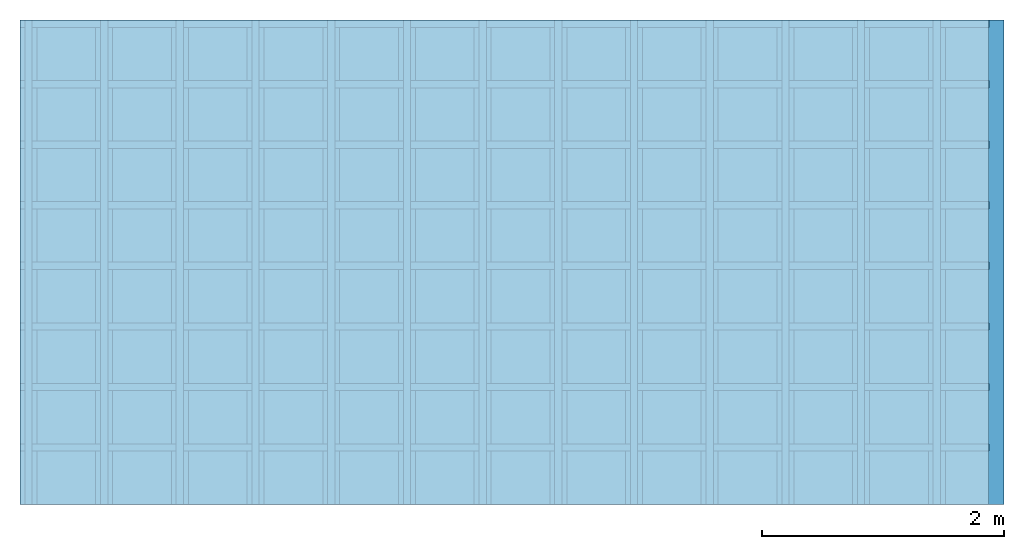
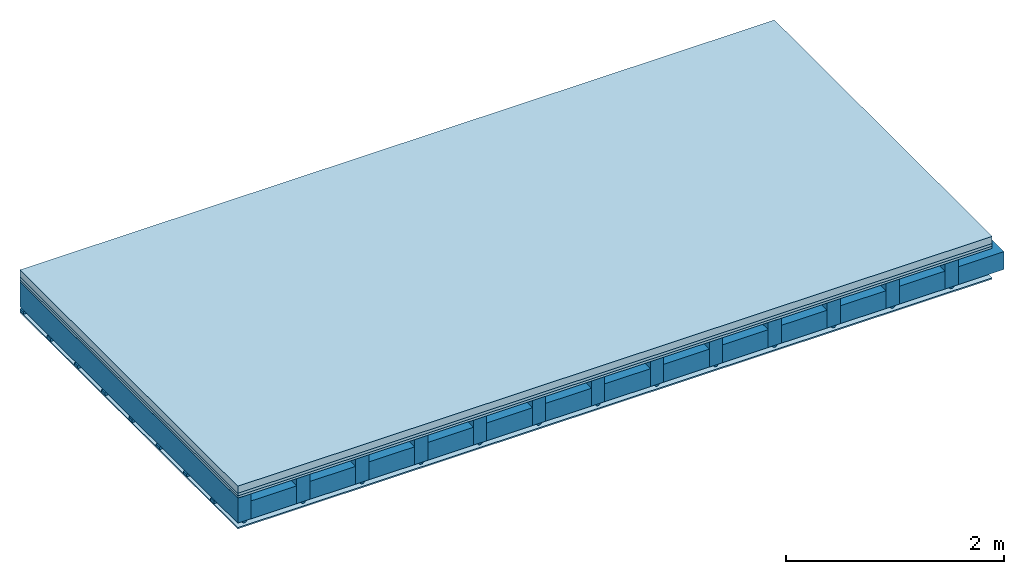
# One storey: 4 members, 4 plates, 1 element without a shape of its own.
"""IFC4 building model written with IfcOpenShell, lengths in metres."""

import ifcopenshell
import ifcopenshell.guid

model = None  # the IFC model being written
_history = None  # IfcOwnerHistory: only IFC2X3 demands one
_inside = {}  # id of a spatial element -> (the spatial element, [elements in it])
_under = {}  # id of a project, library or spatial element -> (it, [spatial elements below it])
_declared = {}  # id of a project -> (the project, [libraries it declares])
_typed = {}  # id of a type object -> (the type object, [elements of that type])
_made_of = {}  # id of a material, layer set ... -> (it, [elements and type objects made of it])


def new_model(schema):
    """Start an empty IFC model of exactly this schema.

    Asked for "IFC4X3", IfcOpenShell would pick the latest addendum, in which some entities
    have other attributes; the version numbers below select the first issue.
    IFC2X3 requires an IfcOwnerHistory on every rooted entity: one is made here for all.
    """
    global model, _history
    if schema == "IFC4X3":
        model = ifcopenshell.file(schema_version=(4, 3, 0, 0))
    else:
        model = ifcopenshell.file(schema=schema)
    _inside.clear()
    _under.clear()
    _declared.clear()
    _typed.clear()
    _made_of.clear()
    _history = None
    if model.schema == "IFC2X3":
        org = make("IfcOrganization", Name="unknown")
        user = make(
            "IfcPersonAndOrganization",
            ThePerson=make("IfcPerson", FamilyName="unknown"),
            TheOrganization=org,
        )
        app = make(
            "IfcApplication",
            ApplicationDeveloper=org,
            Version="unknown",
            ApplicationFullName="unknown",
            ApplicationIdentifier="unknown",
        )
        _history = make(
            "IfcOwnerHistory",
            OwningUser=user,
            OwningApplication=app,
            ChangeAction="ADDED",
            CreationDate=0,
        )
    return model


def make(cls, **values):
    """One entity of the class cls with the attributes given. An attribute that is None is left unset."""
    return model.create_entity(
        cls, **{name: value for name, value in values.items() if value is not None}
    )


def rooted(cls, **values):
    """An entity with a GlobalId (a new one), such as an element, a storey or a relation."""
    return make(cls, GlobalId=ifcopenshell.guid.new(), OwnerHistory=_history, **values)


def si_unit(unit_type, name, prefix=None):
    """IfcSIUnit, for example si_unit("LENGTHUNIT", "METRE", prefix="MILLI")."""
    return make("IfcSIUnit", UnitType=unit_type, Prefix=prefix, Name=name)


def derived_unit(unit_type, elements):
    """IfcDerivedUnit: a product of units, each with its exponent."""
    return make(
        "IfcDerivedUnit",
        Elements=[
            make("IfcDerivedUnitElement", Unit=unit, Exponent=power)
            for unit, power in elements
        ],
        UnitType=unit_type,
    )


def assignment(units):
    """IfcUnitAssignment: the units of a project."""
    return None if units is None else make("IfcUnitAssignment", Units=units)


def point(xyz):
    """IfcCartesianPoint."""
    return None if xyz is None else make("IfcCartesianPoint", Coordinates=xyz)


def direction(xyz):
    """IfcDirection."""
    return None if xyz is None else make("IfcDirection", DirectionRatios=xyz)


def frame(location, z_axis=None, x_axis=None):
    """IfcAxis2Placement3D, a coordinate frame: its origin and axes. An axis left out is left unset."""
    return make(
        "IfcAxis2Placement3D",
        Location=point(location),
        Axis=direction(z_axis),
        RefDirection=direction(x_axis),
    )


def frame_2d(location, x_axis=None):
    """IfcAxis2Placement2D, a coordinate frame in the plane: its origin and x axis."""
    return make(
        "IfcAxis2Placement2D", Location=point(location), RefDirection=direction(x_axis)
    )


def origin():
    """The frame at (0, 0, 0) with its axes left unset."""
    return frame((0.0, 0.0, 0.0))


def origin_with_axes():
    """The frame at (0, 0, 0) with the z axis (0, 0, 1) and the x axis (1, 0, 0) written out."""
    return frame((0.0, 0.0, 0.0), z_axis=(0.0, 0.0, 1.0), x_axis=(1.0, 0.0, 0.0))


def place(relative_to, where):
    """IfcLocalPlacement: puts the frame where relative to a parent placement (None: the world)."""
    return make(
        "IfcLocalPlacement", PlacementRelTo=relative_to, RelativePlacement=where
    )


def context(
    kind, dimensions, precision=None, world=None, true_north=None, identifier=None
):
    """IfcGeometricRepresentationContext, for example the 3D "Model" context."""
    return make(
        "IfcGeometricRepresentationContext",
        ContextIdentifier=identifier,
        ContextType=kind,
        CoordinateSpaceDimension=dimensions,
        Precision=precision,
        WorldCoordinateSystem=world,
        TrueNorth=true_north,
    )


def project(units=None, contexts=None):
    """IfcProject with its units and contexts."""
    return rooted(
        "IfcProject",
        Name="project",
        RepresentationContexts=contexts,
        UnitsInContext=assignment(units),
    )


def spatial(cls, under=None, at=None, **own):
    """A site, building, storey or space (cls), placed at a placement, below another one or the project."""
    s = rooted(cls, ObjectPlacement=at, **own)
    if under is not None:
        _under.setdefault(under.id(), (under, []))[1].append(s)
    return s


def polyline(points):
    """IfcPolyline through the points."""
    return make("IfcPolyline", Points=[point(p) for p in points])


def profile(cls, at=None, kind="AREA", **sizes):
    """A parametric profile (cls). Its sizes go by their IFC names, for example OverallWidth=200.0."""
    return make(cls, ProfileType=kind, Position=at, **sizes)


def rectangle(**sizes):
    """IfcRectangleProfileDef."""
    return profile("IfcRectangleProfileDef", **sizes)


def outline(outer, holes=None, kind="AREA"):
    """IfcArbitraryClosedProfileDef: a profile drawn as a closed curve; with holes, ...WithVoids."""
    if holes is None:
        return make("IfcArbitraryClosedProfileDef", ProfileType=kind, OuterCurve=outer)
    return make(
        "IfcArbitraryProfileDefWithVoids",
        ProfileType=kind,
        OuterCurve=outer,
        InnerCurves=holes,
    )


def extrude(swept, where, along, depth):
    """IfcExtrudedAreaSolid: the profile swept, set in the frame where, extruded along a direction by depth."""
    return make(
        "IfcExtrudedAreaSolid",
        SweptArea=swept,
        Position=where,
        ExtrudedDirection=direction(along),
        Depth=depth,
    )


def shape(context_of_items, identifier, shape_type, items):
    """IfcShapeRepresentation: the items that make up one representation, for example the "Body"."""
    return make(
        "IfcShapeRepresentation",
        ContextOfItems=context_of_items,
        RepresentationIdentifier=identifier,
        RepresentationType=shape_type,
        Items=items,
    )


def material(Name=None, Category=None):
    """IfcMaterial."""
    return make("IfcMaterial", Name=Name, Category=Category)


def layer(
    of_material, thickness, ventilated=None, Name=None, Category=None, Priority=None
):
    """IfcMaterialLayer: one layer of a wall or slab, of a material (None: an air gap)."""
    return make(
        "IfcMaterialLayer",
        Material=of_material,
        LayerThickness=thickness,
        IsVentilated=ventilated,
        Name=Name,
        Category=Category,
        Priority=Priority,
    )


def layer_set(layers, Name=None):
    """IfcMaterialLayerSet."""
    return make("IfcMaterialLayerSet", MaterialLayers=layers, LayerSetName=Name)


def made_of(thing, what):
    """Note that an element or type object is made of a material, layer set ...; save() writes the relation."""
    if what is not None:
        _made_of.setdefault(what.id(), (what, []))[1].append(thing)
    return thing


def type_object(cls, material=None, **own):
    """A type object (cls), such as IfcWallType, which elements share."""
    return made_of(rooted(cls, **own), material)


def element(
    cls,
    number,
    at=None,
    inside=None,
    cuts=None,
    type_object=None,
    material=None,
    context=None,
    identifier="Body",
    shape_type=None,
    held_by="IfcProductDefinitionShape",
    body=None,
    shapes=None,
    **own,
):
    """One element of the class cls, such as IfcWall. Its Tag is "e" and its number.

    at: its placement. inside: the storey or other place that contains it. cuts: it is an
    opening in that element (IfcRelVoidsElement). A single representation is given by context,
    identifier, shape_type and body (its items); several are given by shapes. held_by: the class
    of the entity that holds the representations. save() writes the other relations.
    """
    e = rooted(cls, Tag="e%d" % number, ObjectPlacement=at, **own)
    if body is not None:
        shapes = [shape(context, identifier, shape_type, body)]
    if shapes is not None:
        e.Representation = make(held_by, Representations=shapes)
    if inside is not None:
        _inside.setdefault(inside.id(), (inside, []))[1].append(e)
    if cuts is not None:
        rooted(
            "IfcRelVoidsElement", RelatingBuildingElement=cuts, RelatedOpeningElement=e
        )
    if type_object is not None:
        _typed.setdefault(type_object.id(), (type_object, []))[1].append(e)
    return made_of(e, material)


def aggregate(whole, parts):
    """IfcRelAggregates: a whole, such as a stair, and the parts it consists of."""
    return rooted("IfcRelAggregates", RelatingObject=whole, RelatedObjects=parts)


def save(model, path):
    """Write the relations noted so far, then the file.

    IfcRelAggregates (storeys below a building ...), IfcRelContainedInSpatialStructure (elements
    in a storey), IfcRelDefinesByType, IfcRelAssociatesMaterial and IfcRelDeclares: one each for
    every whole, place, type object, material and project.
    """
    for whole, parts in _under.values():
        aggregate(whole, parts)
    for where, things in _inside.values():
        rooted(
            "IfcRelContainedInSpatialStructure",
            RelatedElements=things,
            RelatingStructure=where,
        )
    for kind, things in _typed.values():
        rooted("IfcRelDefinesByType", RelatedObjects=things, RelatingType=kind)
    for what, things in _made_of.values():
        rooted("IfcRelAssociatesMaterial", RelatedObjects=things, RelatingMaterial=what)
    for by, libraries in _declared.values():
        rooted("IfcRelDeclares", RelatingContext=by, RelatedDefinitions=libraries)
    model.write(path)


model = new_model("IFC4")

# Units and contexts
plan_context = context("Plan", 3, precision=1e-05, world=origin(), true_north=direction((0.0, 1.0)))
model_context = context("Model", 3, precision=1e-05, world=origin(), true_north=direction((0.0, 1.0)))
ifc_project = project(units=[si_unit("LENGTHUNIT", "METRE"), derived_unit("SOUNDPRESSUREUNIT", [(si_unit("PRESSUREUNIT", "PASCAL", prefix="MICRO"), 0)]), si_unit("ENERGYUNIT", "JOULE", prefix="MEGA"), si_unit("MASSUNIT", "GRAM", prefix="KILO"), derived_unit("THERMALTRANSMITTANCEUNIT", [(si_unit("POWERUNIT", "WATT"), 1), (si_unit("AREAUNIT", "SQUARE_METRE"), -1), (si_unit("THERMODYNAMICTEMPERATUREUNIT", "KELVIN"), -1)]), derived_unit("AREADENSITYUNIT", [(si_unit("MASSUNIT", "GRAM", prefix="KILO"), 1), (si_unit("AREAUNIT", "SQUARE_METRE"), -1)]), derived_unit("USERDEFINED", [(si_unit("ENERGYUNIT", "JOULE", prefix="MEGA"), 1), (si_unit("AREAUNIT", "SQUARE_METRE"), -1)])], contexts=[plan_context, model_context])

# Site, building, storey
site = spatial("IfcSite", under=ifc_project)
building_placement = place(None, origin())
building = spatial("IfcBuilding", under=site, at=building_placement)
storey_placement = place(building_placement, origin())
storey = spatial("IfcBuildingStorey", under=building, at=storey_placement)

# Slab, members, plates
ifc_material_1 = material(Name="Cement screed", Category="04.006")
ifc_layer_1 = layer(ifc_material_1, 0.08, Name="On-material")
ifc_material_2 = material()
ifc_layer_2 = layer(ifc_material_2, 0.03, Name="Impact sound insulation")
ifc_material_3 = material(Category="07.001")
ifc_layer_3 = layer(ifc_material_3, 0.025, Name="Sub-floor")
ifc_material_4 = material(Name="of the art")
ifc_layer_4 = layer(ifc_material_4, 0.0, Name="Bond")
ifc_layer_5 = layer(None, 0.28, Name="Supporting structure")
ifc_material_5 = material(Name="no composite action")
ifc_layer_6 = layer(ifc_material_5, 0.0, Name="Bond")
ifc_layer_7 = layer(None, 0.02, Name="Coupling")
ifc_layer_8 = layer(None, 0.03, Name="Battens / profiles")
ifc_material_6 = material(Category="03.007")
ifc_layer_9 = layer(ifc_material_6, 0.015, Name="Ceiling covering 1st layer")
ifc_material_7 = material(Name="Glued joints")
ifc_layer_10 = layer(ifc_material_7, 0.0, Name="Surface / treatment")
ifc_layer_set = layer_set([ifc_layer_1, ifc_layer_2, ifc_layer_3, ifc_layer_4, ifc_layer_5, ifc_layer_6, ifc_layer_7, ifc_layer_8, ifc_layer_9, ifc_layer_10])
slab_type = type_object("IfcSlabType", Name="A0120", PredefinedType="NOTDEFINED", material=ifc_layer_set)
slab_placement = place(None, frame((0.0, 0.0, 0.0), z_axis=(0.0, 0.0, -1.0), x_axis=(1.0, 0.0, 0.0)))
slab = element("IfcSlab", 1, at=slab_placement, inside=storey, type_object=slab_type, material=ifc_layer_set, Name="Slab #1")
ifc_material_8 = material()
member_1_placement = place(slab_placement, origin())
member_1 = element("IfcMember", 2, at=member_1_placement, material=ifc_material_8, Name="Supporting structure", context=plan_context, shape_type="SweptSolid", body=[
    extrude(rectangle(XDim=0.14, YDim=0.28, at=frame_2d((0.07, 0.14), x_axis=(1.0, 0.0))), frame((0.0, 4.0, 0.135), z_axis=(0.0, -1.0, 0.0), x_axis=(1.0, 0.0, 0.0)), (0.0, 0.0, 1.0), 4.0),
    extrude(rectangle(XDim=0.14, YDim=0.28, at=frame_2d((0.07, 0.14), x_axis=(1.0, 0.0))), frame((0.625, 4.0, 0.135), z_axis=(0.0, -1.0, 0.0), x_axis=(1.0, 0.0, 0.0)), (0.0, 0.0, 1.0), 4.0),
    extrude(rectangle(XDim=0.14, YDim=0.28, at=frame_2d((0.07, 0.14), x_axis=(1.0, 0.0))), frame((1.25, 4.0, 0.135), z_axis=(0.0, -1.0, 0.0), x_axis=(1.0, 0.0, 0.0)), (0.0, 0.0, 1.0), 4.0),
    extrude(rectangle(XDim=0.14, YDim=0.28, at=frame_2d((0.07, 0.14), x_axis=(1.0, 0.0))), frame((1.875, 4.0, 0.135), z_axis=(0.0, -1.0, 0.0), x_axis=(1.0, 0.0, 0.0)), (0.0, 0.0, 1.0), 4.0),
    extrude(rectangle(XDim=0.14, YDim=0.28, at=frame_2d((0.07, 0.14), x_axis=(1.0, 0.0))), frame((2.5, 4.0, 0.135), z_axis=(0.0, -1.0, 0.0), x_axis=(1.0, 0.0, 0.0)), (0.0, 0.0, 1.0), 4.0),
    extrude(rectangle(XDim=0.14, YDim=0.28, at=frame_2d((0.07, 0.14), x_axis=(1.0, 0.0))), frame((3.125, 4.0, 0.135), z_axis=(0.0, -1.0, 0.0), x_axis=(1.0, 0.0, 0.0)), (0.0, 0.0, 1.0), 4.0),
    extrude(rectangle(XDim=0.14, YDim=0.28, at=frame_2d((0.07, 0.14), x_axis=(1.0, 0.0))), frame((3.75, 4.0, 0.135), z_axis=(0.0, -1.0, 0.0), x_axis=(1.0, 0.0, 0.0)), (0.0, 0.0, 1.0), 4.0),
    extrude(rectangle(XDim=0.14, YDim=0.28, at=frame_2d((0.07, 0.14), x_axis=(1.0, 0.0))), frame((4.375, 4.0, 0.135), z_axis=(0.0, -1.0, 0.0), x_axis=(1.0, 0.0, 0.0)), (0.0, 0.0, 1.0), 4.0),
    extrude(rectangle(XDim=0.14, YDim=0.28, at=frame_2d((0.07, 0.14), x_axis=(1.0, 0.0))), frame((5.0, 4.0, 0.135), z_axis=(0.0, -1.0, 0.0), x_axis=(1.0, 0.0, 0.0)), (0.0, 0.0, 1.0), 4.0),
    extrude(rectangle(XDim=0.14, YDim=0.28, at=frame_2d((0.07, 0.14), x_axis=(1.0, 0.0))), frame((5.625, 4.0, 0.135), z_axis=(0.0, -1.0, 0.0), x_axis=(1.0, 0.0, 0.0)), (0.0, 0.0, 1.0), 4.0),
    extrude(rectangle(XDim=0.14, YDim=0.28, at=frame_2d((0.07, 0.14), x_axis=(1.0, 0.0))), frame((6.25, 4.0, 0.135), z_axis=(0.0, -1.0, 0.0), x_axis=(1.0, 0.0, 0.0)), (0.0, 0.0, 1.0), 4.0),
    extrude(rectangle(XDim=0.14, YDim=0.28, at=frame_2d((0.07, 0.14), x_axis=(1.0, 0.0))), frame((6.875, 4.0, 0.135), z_axis=(0.0, -1.0, 0.0), x_axis=(1.0, 0.0, 0.0)), (0.0, 0.0, 1.0), 4.0),
    extrude(rectangle(XDim=0.14, YDim=0.28, at=frame_2d((0.07, 0.14), x_axis=(1.0, 0.0))), frame((7.5, 4.0, 0.135), z_axis=(0.0, -1.0, 0.0), x_axis=(1.0, 0.0, 0.0)), (0.0, 0.0, 1.0), 4.0),
])
ifc_material_9 = material()
member_2_placement = place(slab_placement, origin())
member_2 = element("IfcMember", 3, at=member_2_placement, material=ifc_material_9, Name="Cavity", context=plan_context, shape_type="SweptSolid", body=[
    extrude(rectangle(XDim=0.485, YDim=0.2, at=frame_2d((0.2425, 0.1), x_axis=(1.0, 0.0))), frame((0.14, 4.0, 0.215), z_axis=(0.0, -1.0, 0.0), x_axis=(1.0, 0.0, 0.0)), (0.0, 0.0, 1.0), 4.0),
    extrude(rectangle(XDim=0.485, YDim=0.2, at=frame_2d((0.2425, 0.1), x_axis=(1.0, 0.0))), frame((0.765, 4.0, 0.215), z_axis=(0.0, -1.0, 0.0), x_axis=(1.0, 0.0, 0.0)), (0.0, 0.0, 1.0), 4.0),
    extrude(rectangle(XDim=0.485, YDim=0.2, at=frame_2d((0.2425, 0.1), x_axis=(1.0, 0.0))), frame((1.39, 4.0, 0.215), z_axis=(0.0, -1.0, 0.0), x_axis=(1.0, 0.0, 0.0)), (0.0, 0.0, 1.0), 4.0),
    extrude(rectangle(XDim=0.485, YDim=0.2, at=frame_2d((0.2425, 0.1), x_axis=(1.0, 0.0))), frame((2.015, 4.0, 0.215), z_axis=(0.0, -1.0, 0.0), x_axis=(1.0, 0.0, 0.0)), (0.0, 0.0, 1.0), 4.0),
    extrude(rectangle(XDim=0.485, YDim=0.2, at=frame_2d((0.2425, 0.1), x_axis=(1.0, 0.0))), frame((2.64, 4.0, 0.215), z_axis=(0.0, -1.0, 0.0), x_axis=(1.0, 0.0, 0.0)), (0.0, 0.0, 1.0), 4.0),
    extrude(rectangle(XDim=0.485, YDim=0.2, at=frame_2d((0.2425, 0.1), x_axis=(1.0, 0.0))), frame((3.265, 4.0, 0.215), z_axis=(0.0, -1.0, 0.0), x_axis=(1.0, 0.0, 0.0)), (0.0, 0.0, 1.0), 4.0),
    extrude(rectangle(XDim=0.485, YDim=0.2, at=frame_2d((0.2425, 0.1), x_axis=(1.0, 0.0))), frame((3.89, 4.0, 0.215), z_axis=(0.0, -1.0, 0.0), x_axis=(1.0, 0.0, 0.0)), (0.0, 0.0, 1.0), 4.0),
    extrude(rectangle(XDim=0.485, YDim=0.2, at=frame_2d((0.2425, 0.1), x_axis=(1.0, 0.0))), frame((4.515, 4.0, 0.215), z_axis=(0.0, -1.0, 0.0), x_axis=(1.0, 0.0, 0.0)), (0.0, 0.0, 1.0), 4.0),
    extrude(rectangle(XDim=0.485, YDim=0.2, at=frame_2d((0.2425, 0.1), x_axis=(1.0, 0.0))), frame((5.14, 4.0, 0.215), z_axis=(0.0, -1.0, 0.0), x_axis=(1.0, 0.0, 0.0)), (0.0, 0.0, 1.0), 4.0),
    extrude(rectangle(XDim=0.485, YDim=0.2, at=frame_2d((0.2425, 0.1), x_axis=(1.0, 0.0))), frame((5.765, 4.0, 0.215), z_axis=(0.0, -1.0, 0.0), x_axis=(1.0, 0.0, 0.0)), (0.0, 0.0, 1.0), 4.0),
    extrude(rectangle(XDim=0.485, YDim=0.2, at=frame_2d((0.2425, 0.1), x_axis=(1.0, 0.0))), frame((6.39, 4.0, 0.215), z_axis=(0.0, -1.0, 0.0), x_axis=(1.0, 0.0, 0.0)), (0.0, 0.0, 1.0), 4.0),
    extrude(rectangle(XDim=0.485, YDim=0.2, at=frame_2d((0.2425, 0.1), x_axis=(1.0, 0.0))), frame((7.015, 4.0, 0.215), z_axis=(0.0, -1.0, 0.0), x_axis=(1.0, 0.0, 0.0)), (0.0, 0.0, 1.0), 4.0),
    extrude(rectangle(XDim=0.485, YDim=0.2, at=frame_2d((0.2425, 0.1), x_axis=(1.0, 0.0))), frame((7.64, 4.0, 0.215), z_axis=(0.0, -1.0, 0.0), x_axis=(1.0, 0.0, 0.0)), (0.0, 0.0, 1.0), 4.0),
])
ifc_material_10 = material()
member_3_placement = place(slab_placement, origin())
member_3 = element("IfcMember", 4, at=member_3_placement, material=ifc_material_10, Name="Coupling", context=plan_context, shape_type="SweptSolid", body=[
    extrude(outline(polyline([(0.0, 0.0), (0.06, 0.0), (0.04, 0.02), (0.02, 0.02), (0.0, 0.0)])), frame((0.04, 4.0, 0.415), z_axis=(0.0, -1.0, 0.0), x_axis=(1.0, 0.0, 0.0)), (0.0, 0.0, 1.0), 4.0),
    extrude(outline(polyline([(0.0, 0.0), (0.06, 0.0), (0.04, 0.02), (0.02, 0.02), (0.0, 0.0)])), frame((0.665, 4.0, 0.415), z_axis=(0.0, -1.0, 0.0), x_axis=(1.0, 0.0, 0.0)), (0.0, 0.0, 1.0), 4.0),
    extrude(outline(polyline([(0.0, 0.0), (0.06, 0.0), (0.04, 0.02), (0.02, 0.02), (0.0, 0.0)])), frame((1.29, 4.0, 0.415), z_axis=(0.0, -1.0, 0.0), x_axis=(1.0, 0.0, 0.0)), (0.0, 0.0, 1.0), 4.0),
    extrude(outline(polyline([(0.0, 0.0), (0.06, 0.0), (0.04, 0.02), (0.02, 0.02), (0.0, 0.0)])), frame((1.915, 4.0, 0.415), z_axis=(0.0, -1.0, 0.0), x_axis=(1.0, 0.0, 0.0)), (0.0, 0.0, 1.0), 4.0),
    extrude(outline(polyline([(0.0, 0.0), (0.06, 0.0), (0.04, 0.02), (0.02, 0.02), (0.0, 0.0)])), frame((2.54, 4.0, 0.415), z_axis=(0.0, -1.0, 0.0), x_axis=(1.0, 0.0, 0.0)), (0.0, 0.0, 1.0), 4.0),
    extrude(outline(polyline([(0.0, 0.0), (0.06, 0.0), (0.04, 0.02), (0.02, 0.02), (0.0, 0.0)])), frame((3.165, 4.0, 0.415), z_axis=(0.0, -1.0, 0.0), x_axis=(1.0, 0.0, 0.0)), (0.0, 0.0, 1.0), 4.0),
    extrude(outline(polyline([(0.0, 0.0), (0.06, 0.0), (0.04, 0.02), (0.02, 0.02), (0.0, 0.0)])), frame((3.79, 4.0, 0.415), z_axis=(0.0, -1.0, 0.0), x_axis=(1.0, 0.0, 0.0)), (0.0, 0.0, 1.0), 4.0),
    extrude(outline(polyline([(0.0, 0.0), (0.06, 0.0), (0.04, 0.02), (0.02, 0.02), (0.0, 0.0)])), frame((4.415, 4.0, 0.415), z_axis=(0.0, -1.0, 0.0), x_axis=(1.0, 0.0, 0.0)), (0.0, 0.0, 1.0), 4.0),
    extrude(outline(polyline([(0.0, 0.0), (0.06, 0.0), (0.04, 0.02), (0.02, 0.02), (0.0, 0.0)])), frame((5.04, 4.0, 0.415), z_axis=(0.0, -1.0, 0.0), x_axis=(1.0, 0.0, 0.0)), (0.0, 0.0, 1.0), 4.0),
    extrude(outline(polyline([(0.0, 0.0), (0.06, 0.0), (0.04, 0.02), (0.02, 0.02), (0.0, 0.0)])), frame((5.665, 4.0, 0.415), z_axis=(0.0, -1.0, 0.0), x_axis=(1.0, 0.0, 0.0)), (0.0, 0.0, 1.0), 4.0),
    extrude(outline(polyline([(0.0, 0.0), (0.06, 0.0), (0.04, 0.02), (0.02, 0.02), (0.0, 0.0)])), frame((6.29, 4.0, 0.415), z_axis=(0.0, -1.0, 0.0), x_axis=(1.0, 0.0, 0.0)), (0.0, 0.0, 1.0), 4.0),
    extrude(outline(polyline([(0.0, 0.0), (0.06, 0.0), (0.04, 0.02), (0.02, 0.02), (0.0, 0.0)])), frame((6.915, 4.0, 0.415), z_axis=(0.0, -1.0, 0.0), x_axis=(1.0, 0.0, 0.0)), (0.0, 0.0, 1.0), 4.0),
    extrude(outline(polyline([(0.0, 0.0), (0.06, 0.0), (0.04, 0.02), (0.02, 0.02), (0.0, 0.0)])), frame((7.54, 4.0, 0.415), z_axis=(0.0, -1.0, 0.0), x_axis=(1.0, 0.0, 0.0)), (0.0, 0.0, 1.0), 4.0),
])
ifc_material_11 = material()
member_4_placement = place(slab_placement, origin())
member_4 = element("IfcMember", 5, at=member_4_placement, material=ifc_material_11, Name="Battens / profiles", context=plan_context, shape_type="SweptSolid", body=[
    extrude(rectangle(XDim=0.06, YDim=0.03, at=frame_2d((0.03, 0.015), x_axis=(1.0, 0.0))), frame((0.0, 0.0, 0.435), z_axis=(1.0, 0.0, 0.0), x_axis=(0.0, 1.0, 0.0)), (0.0, 0.0, 1.0), 8.0),
    extrude(rectangle(XDim=0.06, YDim=0.03, at=frame_2d((0.03, 0.015), x_axis=(1.0, 0.0))), frame((0.0, 0.5, 0.435), z_axis=(1.0, 0.0, 0.0), x_axis=(0.0, 1.0, 0.0)), (0.0, 0.0, 1.0), 8.0),
    extrude(rectangle(XDim=0.06, YDim=0.03, at=frame_2d((0.03, 0.015), x_axis=(1.0, 0.0))), frame((0.0, 1.0, 0.435), z_axis=(1.0, 0.0, 0.0), x_axis=(0.0, 1.0, 0.0)), (0.0, 0.0, 1.0), 8.0),
    extrude(rectangle(XDim=0.06, YDim=0.03, at=frame_2d((0.03, 0.015), x_axis=(1.0, 0.0))), frame((0.0, 1.5, 0.435), z_axis=(1.0, 0.0, 0.0), x_axis=(0.0, 1.0, 0.0)), (0.0, 0.0, 1.0), 8.0),
    extrude(rectangle(XDim=0.06, YDim=0.03, at=frame_2d((0.03, 0.015), x_axis=(1.0, 0.0))), frame((0.0, 2.0, 0.435), z_axis=(1.0, 0.0, 0.0), x_axis=(0.0, 1.0, 0.0)), (0.0, 0.0, 1.0), 8.0),
    extrude(rectangle(XDim=0.06, YDim=0.03, at=frame_2d((0.03, 0.015), x_axis=(1.0, 0.0))), frame((0.0, 2.5, 0.435), z_axis=(1.0, 0.0, 0.0), x_axis=(0.0, 1.0, 0.0)), (0.0, 0.0, 1.0), 8.0),
    extrude(rectangle(XDim=0.06, YDim=0.03, at=frame_2d((0.03, 0.015), x_axis=(1.0, 0.0))), frame((0.0, 3.0, 0.435), z_axis=(1.0, 0.0, 0.0), x_axis=(0.0, 1.0, 0.0)), (0.0, 0.0, 1.0), 8.0),
    extrude(rectangle(XDim=0.06, YDim=0.03, at=frame_2d((0.03, 0.015), x_axis=(1.0, 0.0))), frame((0.0, 3.5, 0.435), z_axis=(1.0, 0.0, 0.0), x_axis=(0.0, 1.0, 0.0)), (0.0, 0.0, 1.0), 8.0),
])
plate_1_placement = place(slab_placement, origin())
plate_1 = element("IfcPlate", 6, at=plate_1_placement, material=ifc_material_1, Name="On-material", context=plan_context, shape_type="SweptSolid", body=[
    extrude(rectangle(XDim=8.0, YDim=4.0, at=frame_2d((4.0, 2.0), x_axis=(1.0, 0.0))), origin_with_axes(), (0.0, 0.0, 1.0), 0.08),
])
plate_2_placement = place(slab_placement, origin())
plate_2 = element("IfcPlate", 7, at=plate_2_placement, material=ifc_material_2, Name="Impact sound insulation", context=plan_context, shape_type="SweptSolid", body=[
    extrude(rectangle(XDim=8.0, YDim=4.0, at=frame_2d((4.0, 2.0), x_axis=(1.0, 0.0))), frame((0.0, 0.0, 0.08), z_axis=(0.0, 0.0, 1.0), x_axis=(1.0, 0.0, 0.0)), (0.0, 0.0, 1.0), 0.03),
])
plate_3_placement = place(slab_placement, origin())
plate_3 = element("IfcPlate", 8, at=plate_3_placement, material=ifc_material_3, Name="Sub-floor", context=plan_context, shape_type="SweptSolid", body=[
    extrude(rectangle(XDim=8.0, YDim=4.0, at=frame_2d((4.0, 2.0), x_axis=(1.0, 0.0))), frame((0.0, 0.0, 0.11), z_axis=(0.0, 0.0, 1.0), x_axis=(1.0, 0.0, 0.0)), (0.0, 0.0, 1.0), 0.025),
])
plate_4_placement = place(slab_placement, origin())
plate_4 = element("IfcPlate", 9, at=plate_4_placement, material=ifc_material_6, Name="Ceiling covering 1st layer", context=plan_context, shape_type="SweptSolid", body=[
    extrude(rectangle(XDim=8.0, YDim=4.0, at=frame_2d((4.0, 2.0), x_axis=(1.0, 0.0))), frame((0.0, 0.0, 0.465), z_axis=(0.0, 0.0, 1.0), x_axis=(1.0, 0.0, 0.0)), (0.0, 0.0, 1.0), 0.015),
])
aggregate(slab, [plate_1, plate_2, plate_3, member_1, member_2, member_3, member_4, plate_4])

save(model, "model.ifc")
